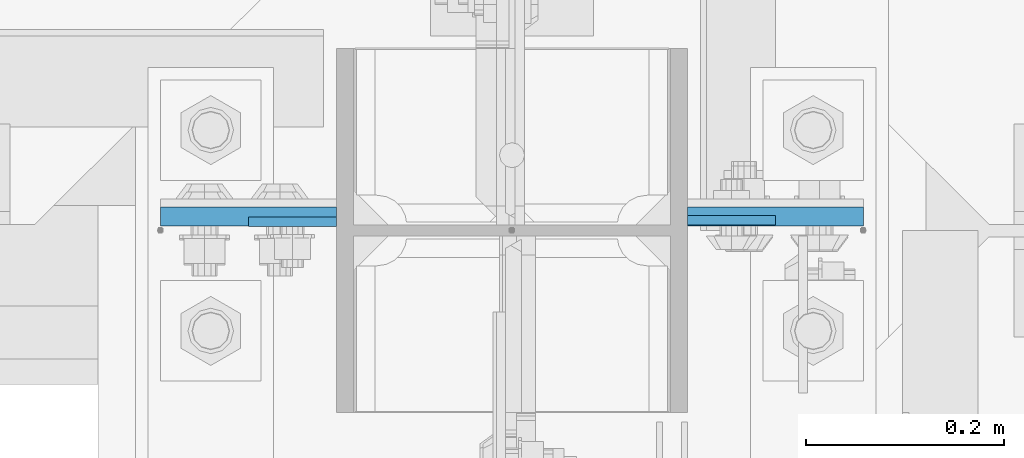
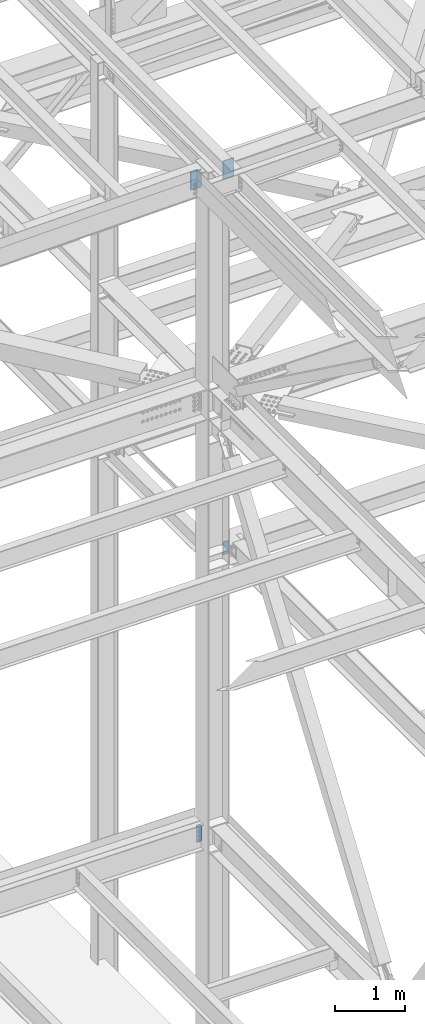
# One storey, part 1501 of 3843: 4 columns, 1 element without a shape of its own.
"""IFC2X3 building model written with IfcOpenShell, lengths in millimetres."""

from ifc_helpers import new_model, si_unit, frame, origin_with_axes, place, context, subcontext, project, spatial, faceted_brep, material, type_object, element, aggregate, save


model = new_model("IFC2X3")

# Units and contexts
model_context = context("Model", 3, precision=1e-05, world=origin_with_axes())
body_context = subcontext(model_context, "Body", "Model", "MODEL_VIEW")
ifc_project = project(units=[si_unit("LENGTHUNIT", "METRE", prefix="MILLI"), si_unit("AREAUNIT", "SQUARE_METRE"), si_unit("VOLUMEUNIT", "CUBIC_METRE"), si_unit("MASSUNIT", "GRAM", prefix="KILO"), si_unit("TIMEUNIT", "SECOND"), si_unit("PLANEANGLEUNIT", "RADIAN"), si_unit("SOLIDANGLEUNIT", "STERADIAN"), si_unit("THERMODYNAMICTEMPERATUREUNIT", "DEGREE_CELSIUS"), si_unit("LUMINOUSINTENSITYUNIT", "LUMEN")], contexts=[model_context])

# Site, building, storey
site_placement = place(None, origin_with_axes())
site = spatial("IfcSite", under=ifc_project, at=site_placement, CompositionType="ELEMENT")
building_placement = place(site_placement, origin_with_axes())
building = spatial("IfcBuilding", under=site, at=building_placement, Name="Undefined", CompositionType="ELEMENT")
storey_placement = place(building_placement, origin_with_axes())
storey = spatial("IfcBuildingStorey", under=building, at=storey_placement, Name="Undefined", CompositionType="ELEMENT", Elevation=0.0)

# Assembly, columns
assembly_placement = place(storey_placement, origin_with_axes())
assembly = element("IfcElementAssembly", 1, at=assembly_placement, inside=storey, Name="COLUMN", AssemblyPlace="NOTDEFINED", PredefinedType="RIGID_FRAME")
ifc_material = material(Name="STEEL/A572-50")
column_type_1 = type_object("IfcColumnType", PredefinedType="NOTDEFINED")
column_1_placement = place(assembly_placement, frame((77279.500000001, 25630.1875, 45916.9103770903), z_axis=(-1.0, 0.0, 0.0), x_axis=(0.0, 0.0, 1.0)))
column_1 = element("IfcColumn", 2, at=column_1_placement, type_object=column_type_1, material=ifc_material, Name="PLATE", context=body_context, shape_type="Brep", body=[
    faceted_brep([(0.0, 9.52500000000146, -88.9000000000015), (0.0, 9.52500000000146, 88.9000000000015), (317.5, 9.52500000000146, 88.9000000000015), (317.5, 9.52500000000146, -88.9000000000015), (0.0, -9.52500000000146, 88.9000000000015), (317.5, -9.52500000000146, 88.9000000000015), (0.0, -9.52500000000146, -88.9000000000015), (317.5, -9.52500000000146, -88.9000000000015)], [[[0, 1, 2, 3]], [[1, 4, 5, 2]], [[4, 6, 7, 5]], [[6, 0, 3, 7]], [[5, 7, 3, 2]], [[6, 4, 1, 0]]]),
])
column_2_placement = place(assembly_placement, frame((76746.099999999, 25630.1875, 45906.9687789878), z_axis=(1.0, 0.0, 0.0), x_axis=(0.0, 0.0, 1.0)))
column_2 = element("IfcColumn", 3, at=column_2_placement, type_object=column_type_1, material=ifc_material, Name="PLATE", context=body_context, shape_type="Brep", body=[
    faceted_brep([(0.0, 9.52500000000146, -88.9000000000015), (0.0, 9.52500000000146, 88.9000000000015), (317.5, 9.52500000000146, 88.9000000000015), (317.5, 9.52500000000146, -88.9000000000015), (0.0, -9.52500000000146, 88.9000000000015), (317.5, -9.52500000000146, 88.9000000000015), (0.0, -9.52500000000146, -88.9000000000015), (317.5, -9.52500000000146, -88.9000000000015)], [[[0, 1, 2, 3]], [[1, 4, 5, 2]], [[4, 6, 7, 5]], [[6, 0, 3, 7]], [[5, 7, 3, 2]], [[6, 4, 1, 0]]]),
])
column_type_2 = type_object("IfcColumnType", PredefinedType="NOTDEFINED")
column_3_placement = place(assembly_placement, frame((76790.55, 25624.63125, 34467.7999993376), z_axis=(1.0, 0.0, 0.0), x_axis=(0.0, 0.0, 1.0)))
column_3 = element("IfcColumn", 4, at=column_3_placement, type_object=column_type_2, material=ifc_material, Name="PLATE", context=body_context, shape_type="Brep", body=[
    faceted_brep([(0.0, 4.76249999999709, -44.4500000000007), (0.0, 4.76249999999709, 44.4500000000007), (304.799999999996, 4.76249999999709, 44.4500000000007), (304.799999999996, 4.76249999999709, -44.4500000000007), (0.0, -4.76249999999709, 44.4500000000007), (304.799999999996, -4.76249999999709, 44.4500000000007), (0.0, -4.76249999999709, -44.4500000000007), (304.799999999996, -4.76249999999709, -44.4500000000007)], [[[0, 1, 2, 3]], [[1, 4, 5, 2]], [[4, 6, 7, 5]], [[6, 0, 3, 7]], [[5, 7, 3, 2]], [[6, 4, 1, 0]]]),
])
column_4_placement = place(assembly_placement, frame((77235.05, 25626.21875, 39344.6), z_axis=(-1.0, 0.0, 0.0), x_axis=(0.0, 0.0, 1.0)))
column_4 = element("IfcColumn", 5, at=column_4_placement, type_object=column_type_2, material=ifc_material, Name="PLATE", context=body_context, shape_type="Brep", body=[
    faceted_brep([(0.0, 4.76249999999709, -44.4500000000007), (0.0, 4.76249999999709, 44.4500000000007), (228.599999999999, 4.76249999999709, 44.4500000000007), (228.599999999999, 4.76249999999709, -44.4500000000007), (0.0, -4.76249999999709, 44.4500000000007), (228.599999999999, -4.76249999999709, 44.4500000000007), (0.0, -4.76249999999709, -44.4500000000007), (228.599999999999, -4.76249999999709, -44.4500000000007)], [[[0, 1, 2, 3]], [[1, 4, 5, 2]], [[4, 6, 7, 5]], [[6, 0, 3, 7]], [[5, 7, 3, 2]], [[6, 4, 1, 0]]]),
])
aggregate(assembly, [column_3, column_1, column_2, column_4])

save(model, "model.ifc")
